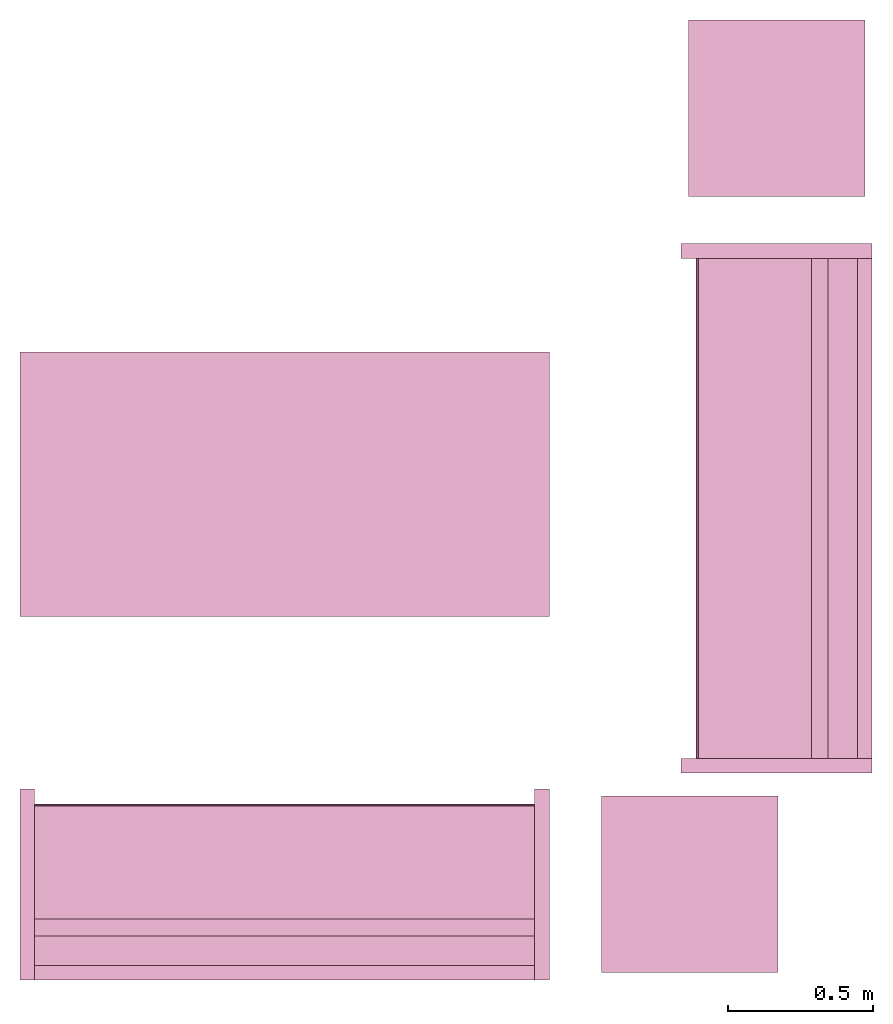
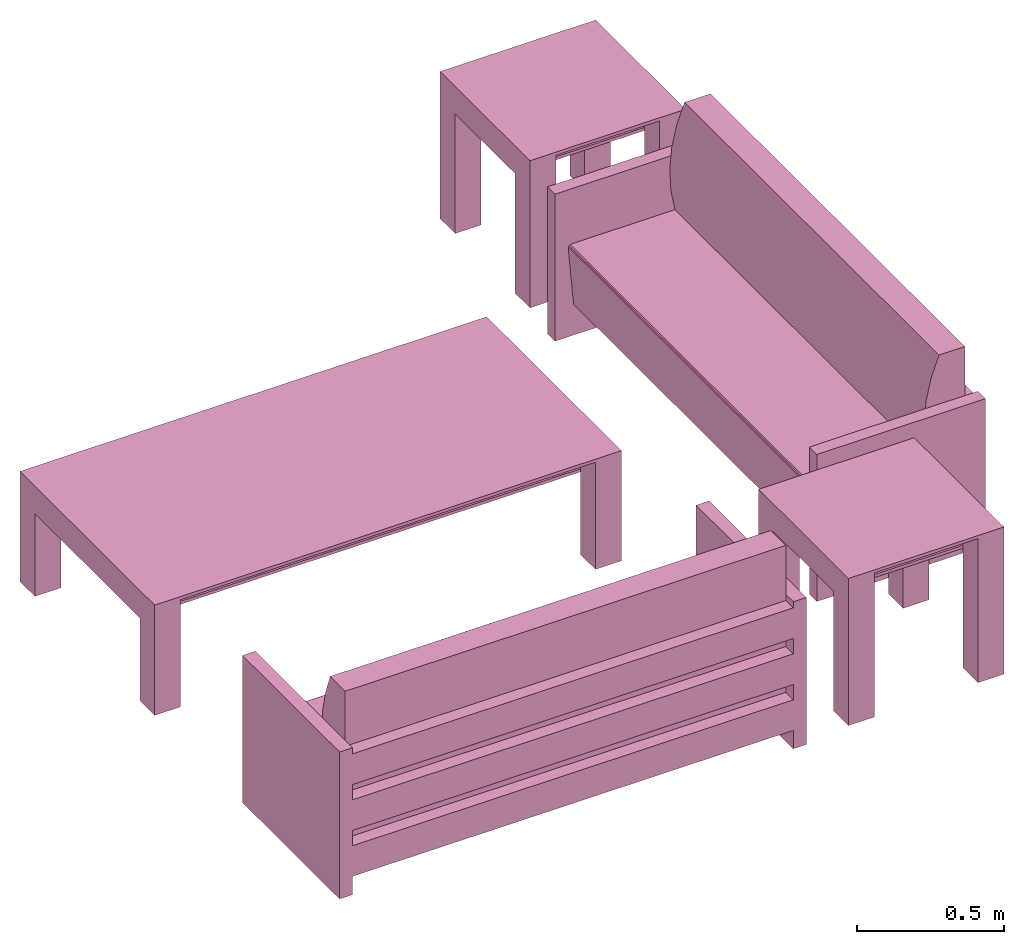
# One storey: 5 furnishings.
"""IFC2X3 building model written with IfcOpenShell, lengths in metres."""

from ifc_helpers import new_model, entity, si_unit, converted_unit, frame, origin, origin_with_axes, origin_2d_with_axis, place, context, project, spatial, polyline, rectangle, outline, extrude, face_set, surface_model, source, transform, mapped, type_object, type_shapes, element, save


model = new_model("IFC2X3")

# Units and contexts
model_context = context("Model", 3, precision=1e-09, world=origin())
plan_context = context("Plan", 3, precision=1e-09, world=origin())
ifc_project = project(units=[si_unit("LENGTHUNIT", "METRE"), si_unit("AREAUNIT", "SQUARE_METRE"), si_unit("VOLUMEUNIT", "CUBIC_METRE"), converted_unit("PLANEANGLEUNIT", "DEGREE", entity("IfcRatioMeasure", 0.0174532925199433), si_unit("PLANEANGLEUNIT", "RADIAN"), dimensions=[0, 0, 0, 0, 0, 0, 0]), si_unit("TIMEUNIT", "SECOND")], contexts=[model_context, plan_context])

# Site, building, storey, space
site_placement = place(None, origin_with_axes())
site = spatial("IfcSite", under=ifc_project, at=site_placement, CompositionType="ELEMENT")
building_placement = place(None, origin_with_axes())
building = spatial("IfcBuilding", under=site, at=building_placement, CompositionType="ELEMENT")
storey_placement = place(None, origin_with_axes())
storey = spatial("IfcBuildingStorey", under=building, at=storey_placement, Name="Level 1", CompositionType="ELEMENT", Elevation=0.0)
space_placement = place(None, origin_with_axes())
space = spatial("IfcSpace", under=storey, at=space_placement, CompositionType="ELEMENT", InteriorOrExteriorSpace="INTERNAL")

# Furnishings
furniture_type_1 = type_object("IfcFurnitureType", Name="1830mm", AssemblyPlace="NOTDEFINED")
shared_shape_1 = source(origin(), model_context, "Body", "SurfaceModel", [
    surface_model("IfcFaceBasedSurfaceModel", [(0.0507999999999982, 0.609599999999997, 0.5842), (0.0507999999999983, 0.660399999999998, 0.5842), (0.0507999999999983, 0.660399999999998, 0.4572), (0.0507999999999982, 0.609599999999997, 0.4572), (0.0507999999999982, 0.609599999999998, 0.3937), (0.0507999999999983, 0.660399999999998, 0.3937), (0.0507999999999983, 0.660399999999998, 0.2667), (0.0507999999999982, 0.609599999999998, 0.2667), (0.0507999999999982, 0.609600000000004, 0.2032), (0.0507999999999983, 0.660399999999998, 0.2032), (0.0507999999999983, 0.660399999999998, 0.0762), (0.0507999999999982, 0.609600000000004, 0.0762), (1.77919999999999, 0.609599999999994, 0.5842), (1.77919999999999, 0.609599999999994, 0.4572), (1.77919999999999, 0.660399999999995, 0.4572), (1.77919999999999, 0.660399999999995, 0.5842), (1.77919999999999, 0.609599999999995, 0.3937), (1.77919999999999, 0.609599999999995, 0.2667), (1.77919999999999, 0.660399999999995, 0.2667), (1.77919999999999, 0.660399999999995, 0.3937), (1.77919999999999, 0.609600000000001, 0.2032), (1.77919999999999, 0.609600000000001, 0.0762), (1.77919999999999, 0.660399999999995, 0.0762), (1.77919999999999, 0.660399999999995, 0.2032), (0.0507999999999978, 0.470222395089521, 0.380999999999998), (0.0507999999999978, 0.454401348887885, 0.467831162756508), (0.0507999999999978, 0.450300415835913, 0.555996567971167), (0.0507999999999978, 0.457992845249543, 0.643921438504357), (0.0507999999999978, 0.477341237862486, 0.730035293556011), (0.0507999999999979, 0.507999999999975, 0.812799999999995), (0.0507999999999981, 0.609599999999998, 0.812799999999998), (0.0507999999999981, 0.609599999999998, 0.127966546684697), (0.0507999999999971, 0.0729375586579064, 0.127966546684697), (0.0507999999999971, 0.0520079452978146, 0.367193122067106), (0.0507999999999971, 0.0526336053189921, 0.372382281209352), (0.0507999999999971, 0.0552961957860913, 0.37687999563672), (0.0507999999999971, 0.0595447350023739, 0.379924455784818), (0.0507999999999971, 0.0646596179635799, 0.381000000000001), (1.77919999999998, 0.470222395089517, 0.381000000000001), (1.77919999999998, 0.0646596179635769, 0.381000000000001), (1.77919999999998, 0.059544735002371, 0.379924455784818), (1.77919999999998, 0.0552961957860883, 0.37687999563672), (1.77919999999998, 0.0526336053189891, 0.372382281209352), (1.77919999999998, 0.0520079452978117, 0.367193122067106), (1.77919999999998, 0.0729375586579034, 0.127966546684697), (1.77919999999998, 0.609599999999995, 0.127966546684697), (1.77919999999998, 0.609599999999995, 0.812799999999998), (1.77919999999998, 0.507999999999972, 0.812799999999995), (1.77919999999998, 0.477341237862483, 0.730035293556011), (1.77919999999998, 0.45799284524954, 0.643921438504357), (1.77919999999998, 0.45030041583591, 0.555996567971167), (1.77919999999998, 0.454401348887882, 0.467831162756508), (0.050799984484911, 0.0539648979902268, 0.374631136655807), (1.77919995784759, 0.0539648979902268, 0.374631136655807), (0.050799984484911, 0.0523207746446133, 0.369787722826004), (1.77919995784759, 0.0523207746446133, 0.369787722826004), (1.77919995784759, 0.0621021725237369, 0.380462229251862), (0.050799984484911, 0.0621788389980793, 0.380478352308273), (1.77919995784759, 0.0574204623699188, 0.378402233123779), (0.050799984484911, 0.0574204623699188, 0.378402233123779), (0.0507999999999971, 0.660399999999997, 0.6096), (0.0507999999999971, 0.0, 0.6096), (0.0, 0.0, 0.6096), (0.0, 0.660399999999997, 0.6096), (1.83, 0.660400000000039, 0.6096), (1.83, 0.0, 0.6096), (1.77919999999997, 0.0, 0.6096), (1.77919999999997, 0.660400000000039, 0.6096), (0.0507999999999971, 0.660399999999997, 0.0), (0.0507999999999971, 0.0, 0.0), (0.0, 0.0, 0.0), (0.0, 0.660399999999997, 0.0), (1.83, 0.660400000000039, 0.0), (1.83, 0.0, 0.0), (1.77919999999997, 0.0, 0.0), (1.77919999999997, 0.660400000000039, 0.0)], [face_set([[[0, 1, 2, 3]], [[4, 5, 6, 7]], [[8, 9, 10, 11]], [[12, 13, 14, 15]], [[16, 17, 18, 19]], [[20, 21, 22, 23]], [[1, 15, 12, 0]], [[2, 14, 15, 1]], [[3, 2, 14, 13]], [[0, 3, 13, 12]], [[5, 19, 16, 4]], [[6, 18, 19, 5]], [[7, 6, 18, 17]], [[4, 7, 17, 16]], [[9, 23, 20, 8]], [[10, 22, 23, 9]], [[11, 10, 22, 21]], [[8, 11, 21, 20]]]), face_set([[[24, 25, 26, 27, 28, 29, 30, 31, 32, 33, 34, 35, 36, 37]], [[38, 39, 40, 41, 42, 43, 44, 45, 46, 47, 48, 49, 50, 51]], [[24, 25, 51, 38]], [[25, 26, 50, 51]], [[49, 50, 26, 27]], [[27, 28, 48, 49]], [[28, 29, 47, 48]], [[30, 46, 47, 29]], [[31, 30, 46, 45]], [[32, 31, 45, 44]], [[33, 32, 44, 43]], [[41, 35, 52, 53]], [[54, 55, 42, 34]], [[33, 43, 55, 54]], [[34, 42, 53, 52]], [[39, 56, 57]], [[35, 41, 58, 59]], [[56, 40, 36]], [[57, 37, 39]], [[57, 56, 36]], [[40, 36, 59, 58]], [[24, 38, 39, 37]]]), face_set([[[60, 61, 62, 63]], [[64, 65, 66, 67]], [[68, 69, 70, 71]], [[72, 73, 74, 75]], [[63, 60, 68, 71]], [[62, 63, 71, 70]], [[61, 62, 70, 69]], [[60, 68, 69, 61]], [[67, 64, 72, 75]], [[66, 74, 75, 67]], [[65, 66, 74, 73]], [[64, 65, 73, 72]]])]),
])
type_shapes(furniture_type_1, [shared_shape_1])
for number, where, z_axis, x_axis, name in (
    (1, (7.6528, -1.38500000000004, 0.0), (0.0, 0.0, 1.0), (0.0, -1.0, 0.0), "M_Sofa:1830mm:1830mm"),
    (2, (7.19799999999998, -3.26980000000002, 0.0), (0.0, 0.0, 1.0), (-1.0, 0.0, 0.0), "M_Sofa:1830mm:1830mm"),
):
    element("IfcFurnishingElement", number, at=place(None, frame(where, z_axis=z_axis, x_axis=x_axis)), inside=space, type_object=furniture_type_1, Name=name, context=model_context, shape_type="MappedRepresentation", body=[
        mapped(shared_shape_1, transform((0.0, 0.0, 0.0), scale=1.0)),
    ])
furniture_type_2 = type_object("IfcFurnitureType", Name="0915 x 1830 x 0457mm", AssemblyPlace="NOTDEFINED")
shared_shape_2 = source(origin(), model_context, "Body", "SweptSolid", [
    extrude(rectangle(XDim=1.6268, YDim=0.711799999999999, at=origin_2d_with_axis()), frame((0.0182657666726317, 0.0952110778022268, 0.3427), z_axis=(0.0, 0.0, 1.0), x_axis=(-1.0, 0.0, 0.0)), (0.0, 0.0, 1.0), 0.0127),
    extrude(outline(polyline([(-0.196749999999994, -0.4575), (0.247549999999978, -0.4575), (0.247549999999978, 0.457499999999999), (-0.196749999999993, 0.457499999999999), (-0.196749999999993, 0.355900000000002), (0.145950000000009, 0.355900000000001), (0.145950000000009, -0.3559), (-0.196749999999994, -0.3559), (-0.196749999999994, -0.4575)])), frame((0.831665766672632, 0.0952110778022354, 0.196749999999991), z_axis=(1.0, 0.0, 0.0), x_axis=(0.0, 0.0, 1.0)), (0.0, 0.0, 1.0), 0.1016),
    extrude(outline(polyline([(-0.457500000000004, -0.247550000000026), (0.457499999999994, -0.247550000000026), (0.457499999999994, 0.196750000000011), (0.355900000000004, 0.196750000000011), (0.355900000000004, -0.145949999999996), (-0.355899999999994, -0.145949999999996), (-0.355899999999994, 0.196750000000011), (-0.457500000000004, 0.196750000000011), (-0.457500000000004, -0.247550000000026)])), frame((-0.896734233327367, 0.0952110778022256, 0.196750000000009), z_axis=(1.0, 0.0, 0.0), x_axis=(0.0, -1.0, 0.0)), (0.0, 0.0, 1.0), 0.1016),
    extrude(rectangle(XDim=1.6268, YDim=0.711799999999999, at=origin_2d_with_axis()), frame((0.0182657666726317, 0.0952110778022265, 0.4443), z_axis=(0.0, 0.0, 1.0), x_axis=(-1.0, 0.0, 0.0)), (0.0, 0.0, 1.0), 0.0127),
    extrude(outline(polyline([(-0.915, -0.457500000000023), (0.915, -0.457500000000023), (0.915, 0.457500000000023), (-0.915, 0.457500000000023), (-0.915, -0.457500000000023)]), holes=[polyline([(-0.813399999999998, -0.355899999999975), (-0.813399999999998, 0.355900000000025), (0.813400000000001, 0.355900000000024), (0.813400000000001, -0.355899999999975), (-0.813399999999998, -0.355899999999975)])]), frame((0.0182657666726332, 0.0952110778022514, 0.4443), z_axis=(0.0, 0.0, 1.0), x_axis=(-1.0, 0.0, 0.0)), (0.0, 0.0, 1.0), 0.0127),
])
type_shapes(furniture_type_2, [shared_shape_2])
furnishing_placement = place(None, frame((6.26473423332737, -2.31221107780226, 0.0), z_axis=(0.0, 0.0, 1.0), x_axis=(1.0, 0.0, 0.0)))
element("IfcFurnishingElement", 3, at=furnishing_placement, inside=space, type_object=furniture_type_2, Name="M_Table-Coffee:0915 x 1830 x 0457mm:0915 x 1830 x 0457mm", context=model_context, shape_type="MappedRepresentation", body=[
    mapped(shared_shape_2, transform((0.0, 0.0, 0.0), scale=1.0)),
])
furniture_type_3 = type_object("IfcFurnitureType", Name="0610 x 0610 x 0610mm", AssemblyPlace="NOTDEFINED")
shared_shape_3 = source(origin(), model_context, "Body", "SweptSolid", [
    extrude(rectangle(XDim=0.406799999999999, YDim=0.406799999999999, at=origin_2d_with_axis()), frame((0.0182657666726316, 0.0952110778022263, 0.4957), z_axis=(0.0, 0.0, 1.0), x_axis=(-1.0, 0.0, 0.0)), (0.0, 0.0, 1.0), 0.0127),
    extrude(outline(polyline([(-0.273249999999994, -0.305), (0.324049999999978, -0.305), (0.324049999999978, 0.304999999999998), (-0.273249999999993, 0.304999999999999), (-0.273249999999993, 0.203400000000001), (0.222450000000009, 0.203400000000001), (0.222450000000009, -0.2034), (-0.273249999999994, -0.2034), (-0.273249999999994, -0.305)])), frame((0.221665766672633, 0.0952110778022354, 0.273249999999992), z_axis=(1.0, 0.0, 0.0), x_axis=(0.0, 0.0, 1.0)), (0.0, 0.0, 1.0), 0.1016),
    extrude(outline(polyline([(-0.305000000000004, -0.324050000000025), (0.304999999999994, -0.324050000000025), (0.304999999999994, 0.273250000000011), (0.203400000000004, 0.273250000000011), (0.203400000000004, -0.222449999999996), (-0.203399999999995, -0.222449999999996), (-0.203399999999995, 0.273250000000011), (-0.305000000000004, 0.273250000000011), (-0.305000000000004, -0.324050000000025)])), frame((-0.286734233327367, 0.0952110778022256, 0.273250000000008), z_axis=(1.0, 0.0, 0.0), x_axis=(0.0, -1.0, 0.0)), (0.0, 0.0, 1.0), 0.1016),
    extrude(rectangle(XDim=0.406799999999999, YDim=0.406799999999999, at=origin_2d_with_axis()), frame((0.0182657666726316, 0.0952110778022259, 0.5973), z_axis=(0.0, 0.0, 1.0), x_axis=(-1.0, 0.0, 0.0)), (0.0, 0.0, 1.0), 0.0127),
    extrude(outline(polyline([(-0.305, -0.305000000000023), (0.305, -0.305000000000023), (0.305, 0.305000000000023), (-0.305, 0.305000000000023), (-0.305, -0.305000000000023)]), holes=[polyline([(-0.203399999999998, -0.203399999999975), (-0.203399999999998, 0.203400000000025), (0.203400000000001, 0.203400000000025), (0.203400000000001, -0.203399999999975), (-0.203399999999998, -0.203399999999975)])]), frame((0.0182657666726332, 0.0952110778022508, 0.5973), z_axis=(0.0, 0.0, 1.0), x_axis=(-1.0, 0.0, 0.0)), (0.0, 0.0, 1.0), 0.0127),
])
type_shapes(furniture_type_3, [shared_shape_3])
for number, where, z_axis, x_axis, name in (
    (4, (7.66473423332737, -3.69521107780226, 0.0), (0.0, 0.0, 1.0), (1.0, 0.0, 0.0), "M_Table-Coffee:0610 x 0610 x 0610mm:0610 x 0610 x 0610mm"),
    (5, (7.96473423332736, -1.01221107780226, 0.0), (0.0, 0.0, 1.0), (1.0, 0.0, 0.0), "M_Table-Coffee:0610 x 0610 x 0610mm:0610 x 0610 x 0610mm"),
):
    element("IfcFurnishingElement", number, at=place(None, frame(where, z_axis=z_axis, x_axis=x_axis)), inside=space, type_object=furniture_type_3, Name=name, context=model_context, shape_type="MappedRepresentation", body=[
        mapped(shared_shape_3, transform((0.0, 0.0, 0.0), scale=1.0)),
    ])

save(model, "model.ifc")
